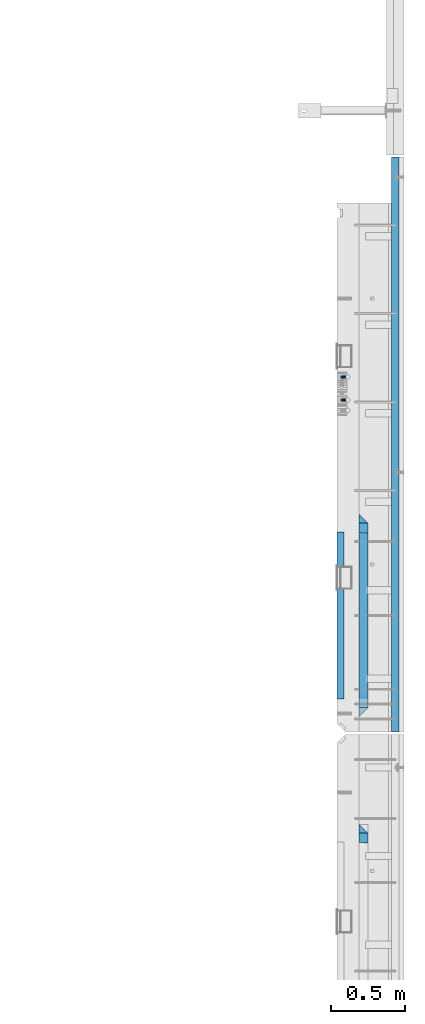
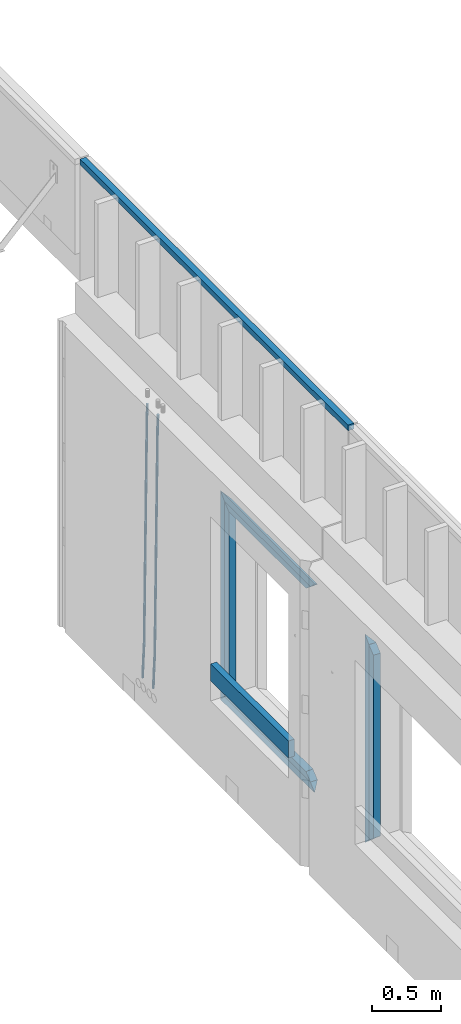
# One storey, part 44 of 153: 12 beams, 2 elements without a shape of their own.
"""IFC2X3 building model written with IfcOpenShell, lengths in millimetres."""

from ifc_helpers import new_model, si_unit, frame, origin_with_axes, place, context, subcontext, project, spatial, faceted_brep, material, type_object, element, aggregate, save


model = new_model("IFC2X3")

# Units and contexts
model_context = context("Model", 3, precision=1e-05, world=origin_with_axes())
body_context = subcontext(model_context, "Body", "Model", "MODEL_VIEW")
ifc_project = project(units=[si_unit("LENGTHUNIT", "METRE", prefix="MILLI"), si_unit("AREAUNIT", "SQUARE_METRE"), si_unit("VOLUMEUNIT", "CUBIC_METRE"), si_unit("MASSUNIT", "GRAM", prefix="KILO"), si_unit("TIMEUNIT", "SECOND"), si_unit("PLANEANGLEUNIT", "RADIAN"), si_unit("SOLIDANGLEUNIT", "STERADIAN"), si_unit("THERMODYNAMICTEMPERATUREUNIT", "DEGREE_CELSIUS"), si_unit("LUMINOUSINTENSITYUNIT", "LUMEN")], contexts=[model_context])

# Site, building, storey
site_placement = place(None, origin_with_axes())
site = spatial("IfcSite", under=ifc_project, at=site_placement, CompositionType="ELEMENT")
building_placement = place(site_placement, origin_with_axes())
building = spatial("IfcBuilding", under=site, at=building_placement, CompositionType="ELEMENT")
storey_placement = place(building_placement, origin_with_axes())
storey = spatial("IfcBuildingStorey", under=building, at=storey_placement, Name="8", CompositionType="ELEMENT", Elevation=0.0)

# Assembly, beams
assembly_1_placement = place(storey_placement, origin_with_axes())
assembly_1 = element("IfcElementAssembly", 1, at=assembly_1_placement, inside=storey, AssemblyPlace="NOTDEFINED", PredefinedType="REINFORCEMENT_UNIT")
ifc_material_1 = material()
beam_type_1 = type_object("IfcBeamType", Name="D20", PredefinedType="NOTDEFINED")
beam_1_placement = place(assembly_1_placement, frame((34944.9999977209, 19395.0002441367, 99990.0), z_axis=(0.999642804629538, 0.000205762999925497, -0.0267249099901003), x_axis=(0.0267249109941254, -4.30000210532798e-08, 0.999642825779465)))
beam_1 = element("IfcBeam", 2, at=beam_1_placement, type_object=beam_type_1, material=ifc_material_1, Name="JM20", ObjectType="D20", context=body_context, shape_type="Brep", body=[
    faceted_brep([(0.0, -10.0, 0.0), (-4.19531716033816e-08, -7.07106781186667, -7.07106781187031), (60.4266690400545, -7.0710677960451, -7.07106780570757), (60.4266690441291, -9.99999998418934, 6.15546014159918e-09), (0.0, 0.0, -10.0), (60.426669036824, 1.58106558956206e-08, -9.99999999384454), (4.196772351861e-08, 7.07106781186303, -7.07106781186667), (60.4266690363438, 7.07106782768096, -7.07106780570757), (0.0, 10.0, 0.0), (60.4266690388904, 10.0000000158179, 6.15182216279209e-09), (4.196772351861e-08, 7.07106781185939, 7.07106781185939), (60.4266690429649, 7.07106782768096, 7.07106781802577), (0.0, 0.0, 10.0), (60.4266690461809, 1.58179318532348e-08, 10.0000000061555), (-4.19531716033816e-08, -7.07106781187031, 7.07106781185939), (60.4266690466611, -7.07106779605238, 7.07106781802213), (61.0378400410118, -7.07106779588503, -7.07106780564936), (60.991799419251, -9.99999998403655, 6.21366780251265e-09), (61.0569027789461, 1.5985278878361e-08, -9.99999999378269), (61.0378209396877, 7.07106782784831, -7.07106780564936), (60.9917724058905, 10.0000000159635, 6.21366780251265e-09), (60.9457317841297, 7.07106782781193, 7.0710678180767), (60.9266690461809, 1.59488990902901e-08, 10.0000000062028), (60.9457508854539, -7.07106779591413, 7.0710678180767), (61.6489592143771, -7.07106614513759, -7.06310863441468), (61.5568818710308, -9.9999984576425, 0.00735959856683621), (61.6870830769039, 1.71821739058942e-06, -9.99179257185824), (61.6489210170112, 7.07106947854481, -7.06310888312146), (61.556827851804, 10.0000015422847, 0.00735924683976918), (61.4647505084577, 7.07106922979438, 7.07782747982128), (61.4266266459163, 1.36643211590126e-06, 10.0065114172685), (61.464788705809, -7.07106639389531, 7.07782772852806), (176.543135720174, -7.07075579406956, -5.56673531796696), (176.451058376813, -9.99968810657447, 1.50373291501455), (176.581259582701, 0.000312069292704109, -8.49541925541052), (176.543097522794, 7.07137982961285, -5.56673556667374), (176.451004357587, 10.00031189336, 1.50373256329476), (176.35892701424, 7.07137958085514, 8.57420079627263), (176.320803151699, 0.000311717507429421, 11.5028847337162), (176.358965211621, -7.07075604281999, 8.57420104497578), (177.098753836006, -7.07075429323595, -5.55949898843028), (176.98362511232, -9.99968666800123, 1.510669025065), (177.146421932586, 0.000313595905026887, -8.48805862247536), (177.098706077581, 7.07138133041735, -5.55949936166144), (176.983557571715, 10.0003133318824, 1.51066849724157), (176.868428848029, 7.07138095712435, 8.58083651073321), (176.820760751449, 0.000313067976094317, 11.5093961447819), (176.868476606425, -7.07075466652896, 8.58083688396073), (177.654312950661, -7.07075204110879, -5.54863964998367), (177.516135294456, -9.99968450931192, 1.52107783331303), (177.711524267797, 0.000315886711177882, -8.47701274570863), (177.654255632195, 7.07138358250813, -5.54864021007961), (177.516054233929, 10.0003154905207, 1.5210770412159), (177.377876577739, 7.0713830223176, 8.59079452451624), (177.320665260588, 0.000315094497636892, 11.5191676202448), (177.377933896176, -7.07075260129932, 8.59079508461218), (299.436796249574, -7.07025836271714, -3.1681962331204), (299.298618593355, -9.99919083092027, 3.90152125031091), (299.494007566798, 0.000809565110102994, -6.09656932889993), (299.436738931283, 7.07187726089978, -3.16819679320906), (299.298537533061, 10.0008091689197, 3.90152045822106), (299.160359876842, 7.07187670072017, 10.9712379416487), (299.103148559603, 0.000808772889286047, 13.8996110374392), (299.160417195119, -7.07025892290039, 10.9712385017483), (299.98743051647, -7.07025613056248, -3.15743315966392), (299.971788958996, -9.99918809853989, 3.91467979818117), (299.993912075952, 0.000811591617093654, -6.08679785393178), (299.987423933868, 7.07187949325817, -3.1574327280432), (299.971753863239, 10.0008119014747, 3.91467990454839), (299.95611230444, 7.07187992653053, 10.9867922621015), (299.949630744944, 0.000812204350950196, 13.9161569563694), (299.956118887014, -7.07025569729012, 10.9867918304735), (300.538107039494, -7.07025785017686, -3.16575821840888), (300.644985195438, -9.99919020432935, 3.90450175465594), (300.493854948218, 0.000810030429420294, -6.09435592770024), (300.538151196495, 7.071877773491, -3.16575855385963), (300.645047642858, 10.0008097955724, 3.90450128024895), (300.751925798773, 7.07187744142357, 10.9747612533101), (300.796177890064, 0.000809560813650023, 13.9033589625978), (300.751881641787, -7.07025818224065, 10.9747615887682), (2293.36490490142, -7.07648090940347, -33.2930642912361), (2293.47178305736, -10.0054132635523, -26.2228043181785), (2293.32065281013, -0.00541302880083094, -36.2216620005347), (2293.36494905842, 7.06565471425711, -33.2930646266868), (2293.47184550477, 9.99458673634581, -26.2228047925819), (2293.57872366071, 7.06565438219332, -19.1525448195243), (2293.62297575199, -0.00541349841296324, -16.2239471102366), (2293.57867950371, -7.0764812414709, -19.1525444840736), (2294.0658245362, -7.07648309818615, -33.3036607065333), (2294.05312277409, -10.0054150789219, -26.2315929392535), (2294.10928714235, -0.00541549149056664, -36.2335844756526), (2294.15805078732, 7.06565223761572, -33.3050546393533), (2294.18355038921, 9.99458451388637, -26.2335642579346), (2294.17084862708, 7.06565253314329, -19.1614964906439), (2294.12738602093, -0.00541507354500936, -16.2315727215355), (2294.07862237596, -7.07648280265857, -19.1601025578348), (2294.76670261032, -7.08562269121467, -33.294332712383), (2294.63442802057, -10.0129954178956, -26.2238563411993), (2294.89787471293, -0.0156988342423574, -36.2230891548279), (2294.95110548967, 7.05531064255774, -33.2944998654275), (2294.89521307347, 9.98530428734011, -26.2240927312887), (2294.76293848372, 7.0579315606592, -19.1536163601049), (2294.63176638114, -0.0119922963167483, -16.2248599176673), (2294.57853560438, -7.08300177311321, -19.1534492070678), (2316.52657204497, -7.36937582653991, -33.0047303660212), (2316.39429745522, -10.2967485532172, -25.9342539948302), (2316.65774414754, -0.299451969567599, -35.9334868084661), (2316.7109749243, 6.7715575072325, -33.0048975190657), (2316.65508250811, 9.70155115201487, -25.9344903849269), (2316.52280791836, 6.7741784253376, -18.8640140137468), (2316.39163581574, -0.295745431634714, -15.9352575713092), (2316.33840503903, -7.36675490843481, -18.863846860706), (2317.16202064224, -7.37766220584308, -32.9962731735213), (2317.05438744847, -10.3053562613532, -25.9254688497131), (2317.23607125619, -0.306993473008333, -35.925789846493), (2317.23316144495, 6.76474808850253, -32.9979477328052), (2317.15499573652, 9.6950321815566, -25.9278370341635), (2317.04736254275, 6.7673381260538, -18.8570327103698), (2316.97331192881, -0.303330606784584, -15.9275160373909), (2316.97622174003, -7.37507216829545, -18.8553581510787), (2317.79752306276, -7.37578610372293, -32.9880110666527), (2317.71453320107, -10.3033876998124, -25.9168792378296), (2317.81444760226, -0.305295583297266, -35.918287695793), (2317.75539265381, 6.76628640723357, -32.9911928173897), (2317.65495180529, 9.69652304524061, -25.9213789128698), (2317.5719619436, 6.76892144914746, -18.8502470840467), (2317.55503740412, -0.301569071270933, -15.9199704549137), (2317.61409235255, -7.3731510618054, -18.847065333317), (2417.8183084176, -7.07752398473531, -31.6906369377139), (2417.73531855589, -10.0051255808248, -24.6195051088798), (2417.83523295709, -0.007033464313281, -34.6209135668432), (2417.77617800863, 7.06454852621755, -31.6938186884508), (2417.67573716014, 9.99478516423187, -24.6240047839383), (2417.59274729842, 7.06718356813872, -17.5528729551006), (2417.57582275895, -0.00330695228694822, -14.6225963259749), (2417.6348777074, -7.07488894281778, -17.5496912043673)], [[[0, 1, 2, 3]], [[1, 4, 5, 2]], [[4, 6, 7, 5]], [[6, 8, 9, 7]], [[8, 10, 11, 9]], [[10, 12, 13, 11]], [[12, 14, 15, 13]], [[14, 0, 3, 15]], [[14, 12, 10, 8, 6, 4, 1, 0]], [[3, 2, 16, 17]], [[2, 5, 18, 16]], [[5, 7, 19, 18]], [[7, 9, 20, 19]], [[9, 11, 21, 20]], [[11, 13, 22, 21]], [[13, 15, 23, 22]], [[15, 3, 17, 23]], [[17, 16, 24, 25]], [[16, 18, 26, 24]], [[18, 19, 27, 26]], [[19, 20, 28, 27]], [[20, 21, 29, 28]], [[21, 22, 30, 29]], [[22, 23, 31, 30]], [[23, 17, 25, 31]], [[25, 24, 32, 33]], [[24, 26, 34, 32]], [[26, 27, 35, 34]], [[27, 28, 36, 35]], [[28, 29, 37, 36]], [[29, 30, 38, 37]], [[30, 31, 39, 38]], [[31, 25, 33, 39]], [[33, 32, 40, 41]], [[32, 34, 42, 40]], [[34, 35, 43, 42]], [[35, 36, 44, 43]], [[36, 37, 45, 44]], [[37, 38, 46, 45]], [[38, 39, 47, 46]], [[39, 33, 41, 47]], [[41, 40, 48, 49]], [[40, 42, 50, 48]], [[42, 43, 51, 50]], [[43, 44, 52, 51]], [[44, 45, 53, 52]], [[45, 46, 54, 53]], [[46, 47, 55, 54]], [[47, 41, 49, 55]], [[49, 48, 56, 57]], [[48, 50, 58, 56]], [[50, 51, 59, 58]], [[51, 52, 60, 59]], [[52, 53, 61, 60]], [[53, 54, 62, 61]], [[54, 55, 63, 62]], [[55, 49, 57, 63]], [[57, 56, 64, 65]], [[56, 58, 66, 64]], [[58, 59, 67, 66]], [[59, 60, 68, 67]], [[60, 61, 69, 68]], [[61, 62, 70, 69]], [[62, 63, 71, 70]], [[63, 57, 65, 71]], [[65, 64, 72, 73]], [[64, 66, 74, 72]], [[66, 67, 75, 74]], [[67, 68, 76, 75]], [[68, 69, 77, 76]], [[69, 70, 78, 77]], [[70, 71, 79, 78]], [[71, 65, 73, 79]], [[73, 72, 80, 81]], [[72, 74, 82, 80]], [[74, 75, 83, 82]], [[75, 76, 84, 83]], [[76, 77, 85, 84]], [[77, 78, 86, 85]], [[78, 79, 87, 86]], [[79, 73, 81, 87]], [[81, 80, 88, 89]], [[80, 82, 90, 88]], [[82, 83, 91, 90]], [[83, 84, 92, 91]], [[84, 85, 93, 92]], [[85, 86, 94, 93]], [[86, 87, 95, 94]], [[87, 81, 89, 95]], [[89, 88, 96, 97]], [[88, 90, 98, 96]], [[90, 91, 99, 98]], [[91, 92, 100, 99]], [[92, 93, 101, 100]], [[93, 94, 102, 101]], [[94, 95, 103, 102]], [[95, 89, 97, 103]], [[97, 96, 104, 105]], [[96, 98, 106, 104]], [[98, 99, 107, 106]], [[99, 100, 108, 107]], [[100, 101, 109, 108]], [[101, 102, 110, 109]], [[102, 103, 111, 110]], [[103, 97, 105, 111]], [[105, 104, 112, 113]], [[104, 106, 114, 112]], [[106, 107, 115, 114]], [[107, 108, 116, 115]], [[108, 109, 117, 116]], [[109, 110, 118, 117]], [[110, 111, 119, 118]], [[111, 105, 113, 119]], [[113, 112, 120, 121]], [[112, 114, 122, 120]], [[114, 115, 123, 122]], [[115, 116, 124, 123]], [[116, 117, 125, 124]], [[117, 118, 126, 125]], [[118, 119, 127, 126]], [[119, 113, 121, 127]], [[121, 120, 128, 129]], [[120, 122, 130, 128]], [[122, 123, 131, 130]], [[123, 124, 132, 131]], [[124, 125, 133, 132]], [[125, 126, 134, 133]], [[126, 127, 135, 134]], [[127, 121, 129, 135]], [[130, 131, 132, 133, 134, 135, 129, 128]]]),
])
beam_2_placement = place(assembly_1_placement, frame((34944.9999977209, 19240.0002441367, 99990.0), z_axis=(0.999642804629538, 0.000205762999925497, -0.0267249099901003), x_axis=(0.0267249109941254, -4.30000210532798e-08, 0.999642825779465)))
beam_2 = element("IfcBeam", 3, at=beam_2_placement, type_object=beam_type_1, material=ifc_material_1, Name="JM20", ObjectType="D20", context=body_context, shape_type="Brep", body=[
    faceted_brep([(0.0, -10.0, 0.0), (-4.19531716033816e-08, -7.07106781186667, -7.07106781187031), (60.4266690400545, -7.0710677960451, -7.07106780570757), (60.4266690441291, -9.99999998418934, 6.15546014159918e-09), (0.0, 0.0, -10.0), (60.426669036824, 1.58106558956206e-08, -9.99999999384454), (4.196772351861e-08, 7.07106781186303, -7.07106781186667), (60.4266690363438, 7.07106782768096, -7.07106780570757), (0.0, 10.0, 0.0), (60.4266690388904, 10.0000000158179, 6.15182216279209e-09), (4.196772351861e-08, 7.07106781185939, 7.07106781185939), (60.4266690429649, 7.07106782768096, 7.07106781802577), (0.0, 0.0, 10.0), (60.4266690461809, 1.58179318532348e-08, 10.0000000061555), (-4.19531716033816e-08, -7.07106781187031, 7.07106781185939), (60.4266690466611, -7.07106779605238, 7.07106781802213), (61.0378400410118, -7.07106779588503, -7.07106780564936), (60.991799419251, -9.99999998403655, 6.21366780251265e-09), (61.0569027789461, 1.5985278878361e-08, -9.99999999378269), (61.0378209396877, 7.07106782784831, -7.07106780564936), (60.9917724058905, 10.0000000159635, 6.21366780251265e-09), (60.9457317841297, 7.07106782781193, 7.0710678180767), (60.9266690461809, 1.59488990902901e-08, 10.0000000062028), (60.9457508854539, -7.07106779591413, 7.0710678180767), (61.6489592143771, -7.07106614513759, -7.06310863441468), (61.5568818710308, -9.9999984576425, 0.00735959856683621), (61.6870830769039, 1.71821739058942e-06, -9.99179257185824), (61.6489210170112, 7.07106947854481, -7.06310888312146), (61.556827851804, 10.0000015422847, 0.00735924683976918), (61.4647505084577, 7.07106922979438, 7.07782747982128), (61.4266266459163, 1.36643211590126e-06, 10.0065114172685), (61.464788705809, -7.07106639389531, 7.07782772852806), (176.543135720174, -7.07075579406956, -5.56673531796696), (176.451058376813, -9.99968810657447, 1.50373291501455), (176.581259582701, 0.000312069292704109, -8.49541925541052), (176.543097522794, 7.07137982961285, -5.56673556667374), (176.451004357587, 10.00031189336, 1.50373256329476), (176.35892701424, 7.07137958085514, 8.57420079627263), (176.320803151699, 0.000311717507429421, 11.5028847337162), (176.358965211621, -7.07075604281999, 8.57420104497578), (177.098753836006, -7.07075429323595, -5.55949898843028), (176.98362511232, -9.99968666800123, 1.510669025065), (177.146421932586, 0.000313595905026887, -8.48805862247536), (177.098706077581, 7.07138133041735, -5.55949936166144), (176.983557571715, 10.0003133318824, 1.51066849724157), (176.868428848029, 7.07138095712435, 8.58083651073321), (176.820760751449, 0.000313067976094317, 11.5093961447819), (176.868476606425, -7.07075466652896, 8.58083688396073), (177.654312950661, -7.07075204110879, -5.54863964998367), (177.516135294456, -9.99968450931192, 1.52107783331303), (177.711524267797, 0.000315886711177882, -8.47701274570863), (177.654255632195, 7.07138358250813, -5.54864021007961), (177.516054233929, 10.0003154905207, 1.5210770412159), (177.377876577739, 7.0713830223176, 8.59079452451624), (177.320665260588, 0.000315094497636892, 11.5191676202448), (177.377933896176, -7.07075260129932, 8.59079508461218), (299.436796249574, -7.07025836271714, -3.1681962331204), (299.298618593355, -9.99919083092027, 3.90152125031091), (299.494007566798, 0.000809565110102994, -6.09656932889993), (299.436738931283, 7.07187726089978, -3.16819679320906), (299.298537533061, 10.0008091689197, 3.90152045822106), (299.160359876842, 7.07187670072017, 10.9712379416487), (299.103148559603, 0.000808772889286047, 13.8996110374392), (299.160417195119, -7.07025892290039, 10.9712385017483), (299.98743051647, -7.07025613056248, -3.15743315966392), (299.971788958996, -9.99918809853989, 3.91467979818117), (299.993912075952, 0.000811591617093654, -6.08679785393178), (299.987423933868, 7.07187949325817, -3.1574327280432), (299.971753863239, 10.0008119014747, 3.91467990454839), (299.95611230444, 7.07187992653053, 10.9867922621015), (299.949630744944, 0.000812204350950196, 13.9161569563694), (299.956118887014, -7.07025569729012, 10.9867918304735), (300.538107039494, -7.07025785017686, -3.16575821840888), (300.644985195438, -9.99919020432935, 3.90450175465594), (300.493854948218, 0.000810030429420294, -6.09435592770024), (300.538151196495, 7.071877773491, -3.16575855385963), (300.645047642858, 10.0008097955724, 3.90450128024895), (300.751925798773, 7.07187744142357, 10.9747612533101), (300.796177890064, 0.000809560813650023, 13.9033589625978), (300.751881641787, -7.07025818224065, 10.9747615887682), (2293.36490490142, -7.07648090940347, -33.2930642912361), (2293.47178305736, -10.0054132635523, -26.2228043181785), (2293.32065281013, -0.00541302880083094, -36.2216620005347), (2293.36494905842, 7.06565471425711, -33.2930646266868), (2293.47184550477, 9.99458673634581, -26.2228047925819), (2293.57872366071, 7.06565438219332, -19.1525448195243), (2293.62297575199, -0.00541349841296324, -16.2239471102366), (2293.57867950371, -7.0764812414709, -19.1525444840736), (2294.0658245362, -7.07648309818615, -33.3036607065333), (2294.05312277409, -10.0054150789219, -26.2315929392535), (2294.10928714235, -0.00541549149056664, -36.2335844756526), (2294.15805078732, 7.06565223761572, -33.3050546393533), (2294.18355038921, 9.99458451388637, -26.2335642579346), (2294.17084862708, 7.06565253314329, -19.1614964906439), (2294.12738602093, -0.00541507354500936, -16.2315727215355), (2294.07862237596, -7.07648280265857, -19.1601025578348), (2294.76670261032, -7.08562269121467, -33.294332712383), (2294.63442802057, -10.0129954178956, -26.2238563411993), (2294.89787471293, -0.0156988342423574, -36.2230891548279), (2294.95110548967, 7.05531064255774, -33.2944998654275), (2294.89521307347, 9.98530428734011, -26.2240927312887), (2294.76293848372, 7.0579315606592, -19.1536163601049), (2294.63176638114, -0.0119922963167483, -16.2248599176673), (2294.57853560438, -7.08300177311321, -19.1534492070678), (2316.52657204497, -7.36937582653991, -33.0047303660212), (2316.39429745522, -10.2967485532172, -25.9342539948302), (2316.65774414754, -0.299451969567599, -35.9334868084661), (2316.7109749243, 6.7715575072325, -33.0048975190657), (2316.65508250811, 9.70155115201487, -25.9344903849269), (2316.52280791836, 6.7741784253376, -18.8640140137468), (2316.39163581574, -0.295745431634714, -15.9352575713092), (2316.33840503903, -7.36675490843481, -18.863846860706), (2317.16202064224, -7.37766220584308, -32.9962731735213), (2317.05438744847, -10.3053562613532, -25.9254688497131), (2317.23607125619, -0.306993473008333, -35.925789846493), (2317.23316144495, 6.76474808850253, -32.9979477328052), (2317.15499573652, 9.6950321815566, -25.9278370341635), (2317.04736254275, 6.7673381260538, -18.8570327103698), (2316.97331192881, -0.303330606784584, -15.9275160373909), (2316.97622174003, -7.37507216829545, -18.8553581510787), (2317.79752306276, -7.37578610372293, -32.9880110666527), (2317.71453320107, -10.3033876998124, -25.9168792378296), (2317.81444760226, -0.305295583297266, -35.918287695793), (2317.75539265381, 6.76628640723357, -32.9911928173897), (2317.65495180529, 9.69652304524061, -25.9213789128698), (2317.5719619436, 6.76892144914746, -18.8502470840467), (2317.55503740412, -0.301569071270933, -15.9199704549137), (2317.61409235255, -7.3731510618054, -18.847065333317), (2417.8183084176, -7.07752398473531, -31.6906369377139), (2417.73531855589, -10.0051255808248, -24.6195051088798), (2417.83523295709, -0.007033464313281, -34.6209135668432), (2417.77617800863, 7.06454852621755, -31.6938186884508), (2417.67573716014, 9.99478516423187, -24.6240047839383), (2417.59274729842, 7.06718356813872, -17.5528729551006), (2417.57582275895, -0.00330695228694822, -14.6225963259749), (2417.6348777074, -7.07488894281778, -17.5496912043673)], [[[0, 1, 2, 3]], [[1, 4, 5, 2]], [[4, 6, 7, 5]], [[6, 8, 9, 7]], [[8, 10, 11, 9]], [[10, 12, 13, 11]], [[12, 14, 15, 13]], [[14, 0, 3, 15]], [[14, 12, 10, 8, 6, 4, 1, 0]], [[3, 2, 16, 17]], [[2, 5, 18, 16]], [[5, 7, 19, 18]], [[7, 9, 20, 19]], [[9, 11, 21, 20]], [[11, 13, 22, 21]], [[13, 15, 23, 22]], [[15, 3, 17, 23]], [[17, 16, 24, 25]], [[16, 18, 26, 24]], [[18, 19, 27, 26]], [[19, 20, 28, 27]], [[20, 21, 29, 28]], [[21, 22, 30, 29]], [[22, 23, 31, 30]], [[23, 17, 25, 31]], [[25, 24, 32, 33]], [[24, 26, 34, 32]], [[26, 27, 35, 34]], [[27, 28, 36, 35]], [[28, 29, 37, 36]], [[29, 30, 38, 37]], [[30, 31, 39, 38]], [[31, 25, 33, 39]], [[33, 32, 40, 41]], [[32, 34, 42, 40]], [[34, 35, 43, 42]], [[35, 36, 44, 43]], [[36, 37, 45, 44]], [[37, 38, 46, 45]], [[38, 39, 47, 46]], [[39, 33, 41, 47]], [[41, 40, 48, 49]], [[40, 42, 50, 48]], [[42, 43, 51, 50]], [[43, 44, 52, 51]], [[44, 45, 53, 52]], [[45, 46, 54, 53]], [[46, 47, 55, 54]], [[47, 41, 49, 55]], [[49, 48, 56, 57]], [[48, 50, 58, 56]], [[50, 51, 59, 58]], [[51, 52, 60, 59]], [[52, 53, 61, 60]], [[53, 54, 62, 61]], [[54, 55, 63, 62]], [[55, 49, 57, 63]], [[57, 56, 64, 65]], [[56, 58, 66, 64]], [[58, 59, 67, 66]], [[59, 60, 68, 67]], [[60, 61, 69, 68]], [[61, 62, 70, 69]], [[62, 63, 71, 70]], [[63, 57, 65, 71]], [[65, 64, 72, 73]], [[64, 66, 74, 72]], [[66, 67, 75, 74]], [[67, 68, 76, 75]], [[68, 69, 77, 76]], [[69, 70, 78, 77]], [[70, 71, 79, 78]], [[71, 65, 73, 79]], [[73, 72, 80, 81]], [[72, 74, 82, 80]], [[74, 75, 83, 82]], [[75, 76, 84, 83]], [[76, 77, 85, 84]], [[77, 78, 86, 85]], [[78, 79, 87, 86]], [[79, 73, 81, 87]], [[81, 80, 88, 89]], [[80, 82, 90, 88]], [[82, 83, 91, 90]], [[83, 84, 92, 91]], [[84, 85, 93, 92]], [[85, 86, 94, 93]], [[86, 87, 95, 94]], [[87, 81, 89, 95]], [[89, 88, 96, 97]], [[88, 90, 98, 96]], [[90, 91, 99, 98]], [[91, 92, 100, 99]], [[92, 93, 101, 100]], [[93, 94, 102, 101]], [[94, 95, 103, 102]], [[95, 89, 97, 103]], [[97, 96, 104, 105]], [[96, 98, 106, 104]], [[98, 99, 107, 106]], [[99, 100, 108, 107]], [[100, 101, 109, 108]], [[101, 102, 110, 109]], [[102, 103, 111, 110]], [[103, 97, 105, 111]], [[105, 104, 112, 113]], [[104, 106, 114, 112]], [[106, 107, 115, 114]], [[107, 108, 116, 115]], [[108, 109, 117, 116]], [[109, 110, 118, 117]], [[110, 111, 119, 118]], [[111, 105, 113, 119]], [[113, 112, 120, 121]], [[112, 114, 122, 120]], [[114, 115, 123, 122]], [[115, 116, 124, 123]], [[116, 117, 125, 124]], [[117, 118, 126, 125]], [[118, 119, 127, 126]], [[119, 113, 121, 127]], [[121, 120, 128, 129]], [[120, 122, 130, 128]], [[122, 123, 131, 130]], [[123, 124, 132, 131]], [[124, 125, 133, 132]], [[125, 126, 134, 133]], [[126, 127, 135, 134]], [[127, 121, 129, 135]], [[130, 131, 132, 133, 134, 135, 129, 128]]]),
])
ifc_material_2 = material(Name="TIMBER/T24")
beam_type_2 = type_object("IfcBeamType", Name="PK50X50", PredefinedType="NOTDEFINED")
beam_3_placement = place(assembly_1_placement, frame((35305.0, 20885.0002441406, 103545.0), z_axis=(0.0, 0.0, 1.0), x_axis=(0.0, -1.0, 0.0)))
beam_3 = element("IfcBeam", 4, at=beam_3_placement, type_object=beam_type_2, material=ifc_material_2, ObjectType="PK50X50", context=body_context, shape_type="Brep", body=[
    faceted_brep([(0.0, 25.0, 25.0), (0.0, -25.0, 25.0), (3895.0, -25.0, 25.0), (3895.0, 25.0, 25.0), (0.0, -25.0, -25.0), (3895.0, -25.0, -25.0), (0.0, 25.0, -25.0), (3895.0, 25.0, -25.0)], [[[0, 1, 2, 3]], [[1, 4, 5, 2]], [[4, 6, 7, 5]], [[6, 0, 3, 7]], [[5, 7, 3, 2]], [[4, 1, 0, 6]]]),
])
beam_type_3 = type_object("IfcBeamType", PredefinedType="NOTDEFINED")
beam_4_placement = place(assembly_1_placement, frame((34935.0002758707, 17215.0011464907, 100685.0), z_axis=(0.0, 0.0, 1.0), x_axis=(0.0, 1.0, 0.0)))
beam_4 = element("IfcBeam", 5, at=beam_4_placement, type_object=beam_type_3, material=ifc_material_2, context=body_context, shape_type="Brep", body=[
    faceted_brep([(-3.63797880709171e-12, 24.9999999999964, -75.0), (-3.63797880709171e-12, 24.9999999999964, 75.0), (1130.0, 25.0, 75.0), (1130.0, 25.0, -75.0), (0.0, -25.0000000000073, 75.0), (1130.0, -25.0, 75.0), (0.0, -25.0000000000073, -75.0), (1130.0, -25.0, -75.0)], [[[0, 1, 2, 3]], [[1, 4, 5, 2]], [[4, 6, 7, 5]], [[6, 0, 3, 7]], [[5, 7, 3, 2]], [[6, 4, 1, 0]]]),
])
ifc_material_3 = material(Name="CONCRETE/C25/30")
beam_type_4 = type_object("IfcBeamType", PredefinedType="NOTDEFINED")
beam_5_placement = place(assembly_1_placement, frame((35090.0, 17095.0018965848, 102145.0), z_axis=(0.0, 0.0, -1.0), x_axis=(0.0, 1.0, 0.0)))
beam_5 = element("IfcBeam", 6, at=beam_5_placement, type_object=beam_type_4, material=ifc_material_3, Name="SK", context=body_context, shape_type="Brep", body=[
    faceted_brep([(60.0000000000073, 30.0, 30.0), (0.0, -30.0, -30.0), (60.0000000000073, -30.0, 30.0), (1309.99847412109, 30.0, 30.0), (1369.99847412109, -30.0, -30.0), (1309.99847412109, -30.0, 30.0)], [[[0, 1, 2]], [[1, 0, 3, 4]], [[2, 1, 4, 5]], [[0, 2, 5, 3]], [[3, 5, 4]]]),
])
beam_6_placement = place(assembly_1_placement, frame((35090.0, 17155.0018965848, 102085.0), z_axis=(0.0, 0.0, -1.0), x_axis=(0.0, 1.0, 0.0)))
beam_6 = element("IfcBeam", 7, at=beam_6_placement, type_object=beam_type_4, material=ifc_material_3, Name="SK", context=body_context, shape_type="Brep", body=[
    faceted_brep([(1185.94442006696, -29.999999998452, 24.0540540541406), (1184.32279844542, 29.999999998452, 25.6756756756804), (65.6741497967687, 29.999999998452, 25.6756756756804), (64.0525281752307, -29.999999998452, 24.0540540541406), (65.6741497967687, 29.999999998452, 26.2921283848846), (64.0525281752307, -29.999999998452, 24.9021669953072), (0.0, 30.0, -30.0), (0.0, -30.0, -30.0), (1249.99847412109, 29.999999998452, -30.0), (1249.99847412109, -29.999999998452, -30.0), (1185.94442006696, -29.999999998452, 24.9034748915001), (1184.32279844542, 29.999999998452, 26.2934362810629)], [[[0, 1, 2, 3]], [[3, 2, 4, 5]], [[4, 6, 7, 5]], [[7, 6, 8, 9]], [[0, 3, 5, 7, 9, 10]], [[1, 0, 10, 11]], [[6, 4, 2, 1, 11, 8]], [[8, 11, 10, 9]]]),
])
beam_7_placement = place(assembly_1_placement, frame((35090.0, 18435.0003707059, 102175.0), z_axis=(0.0, -1.0, 0.0), x_axis=(0.0, 0.0, -1.0)))
beam_7 = element("IfcBeam", 8, at=beam_7_placement, type_object=beam_type_4, material=ifc_material_3, Name="SK", context=body_context, shape_type="Brep", body=[
    faceted_brep([(60.0000000000073, 30.0, 30.0), (0.0, -30.0, -30.0), (60.0000000000073, -30.0, 30.0), (1795.00000000001, 30.0, 30.0), (1855.0, -30.0, -30.0), (1795.00000000001, -30.0, 30.0)], [[[0, 1, 2]], [[3, 4, 1, 0]], [[4, 5, 2, 1]], [[5, 3, 0, 2]], [[5, 4, 3]]]),
])
beam_8_placement = place(assembly_1_placement, frame((35090.0, 18465.0003707059, 100350.0), z_axis=(0.0, 0.0, 1.0), x_axis=(0.0, -1.0, 0.0)))
beam_8 = element("IfcBeam", 9, at=beam_8_placement, type_object=beam_type_4, material=ifc_material_3, Name="SK", context=body_context, shape_type="Brep", body=[
    faceted_brep([(1309.99847412109, 30.0, 30.0), (1309.99847412109, -30.0, 30.0), (1369.99847412109, -30.0, -30.0), (60.0000000000073, 30.0, 30.0), (60.0000000000073, -30.0, 30.0), (0.0, -30.0, -30.0)], [[[0, 1, 2]], [[3, 4, 1, 0]], [[4, 5, 2, 1]], [[5, 3, 0, 2]], [[3, 5, 4]]]),
])
beam_9_placement = place(assembly_1_placement, frame((35090.0, 18405.0003707059, 100410.0), z_axis=(0.0, 0.0, 1.0), x_axis=(0.0, -1.0, 0.0)))
beam_9 = element("IfcBeam", 10, at=beam_9_placement, type_object=beam_type_4, material=ifc_material_3, Name="SK", context=body_context, shape_type="Brep", body=[
    faceted_brep([(1185.94594588314, -29.9999988381387, 24.0540541168593), (1184.32432432432, 29.9999988381387, 25.6756756756804), (65.6756756756768, 30.0, 25.6756756756804), (64.0540540540533, -30.0, 24.0540540540533), (1185.94594594586, -29.999999998452, 24.9021669952926), (1184.32432432433, 29.999999998452, 26.2921283848846), (1249.99847412109, -29.999999998452, -30.0), (1249.99847412109, 29.999999998452, -30.0), (0.0, 30.0, -30.0), (65.6756756756768, 30.0, 26.293436281092), (64.0540540540533, -30.0, 24.9034748914419), (0.0, -30.0, -30.0)], [[[0, 1, 2, 3]], [[1, 0, 4, 5]], [[5, 4, 6, 7]], [[2, 1, 5, 7, 8, 9]], [[3, 2, 9, 10]], [[6, 4, 0, 3, 10, 11]], [[11, 8, 7, 6]], [[11, 10, 9, 8]]]),
])

# Assembly, beam
assembly_2_placement = place(storey_placement, origin_with_axes())
assembly_2 = element("IfcElementAssembly", 11, at=assembly_2_placement, inside=storey, AssemblyPlace="NOTDEFINED", PredefinedType="REINFORCEMENT_UNIT")
beam_10_placement = place(assembly_2_placement, frame((35090.0, 16335.0003479451, 102175.0), z_axis=(0.0, -1.0, 0.0), x_axis=(0.0, 0.0, -1.0)))
beam_10 = element("IfcBeam", 12, at=beam_10_placement, type_object=beam_type_4, material=ifc_material_3, Name="SK", context=body_context, shape_type="Brep", body=[
    faceted_brep([(60.0000000000073, 30.0, 30.0), (0.0, -30.0, -30.0), (60.0000000000073, -30.0, 30.0), (1795.00000000001, 30.0, 30.0), (1855.0, -30.0, -30.0), (1795.00000000001, -30.0, 30.0)], [[[0, 1, 2]], [[3, 4, 1, 0]], [[4, 5, 2, 1]], [[5, 3, 0, 2]], [[5, 4, 3]]]),
])

# Beam
beam_type_5 = type_object("IfcBeamType", PredefinedType="NOTDEFINED")
beam_11_placement = place(assembly_1_placement, frame((35090.0, 18370.0003707059, 102115.0), z_axis=(0.0, -1.0, 0.0), x_axis=(0.0, 0.0, -1.0)))
beam_11 = element("IfcBeam", 13, at=beam_11_placement, type_object=beam_type_5, material=ifc_material_3, Name="SK", context=body_context, shape_type="Brep", body=[
    faceted_brep([(0.0, -30.0, -35.0), (54.9034748914273, -30.0, 29.0540540540533), (56.2934362811066, 30.0, 30.6756756756768), (0.0, 30.0, -35.0), (1735.0, 30.0, -35.0), (1735.0, -30.0, -35.0), (1680.09652510857, -30.0, 29.0540540540533), (1678.70656371891, 30.0, 30.6756756756768)], [[[0, 1, 2, 3]], [[4, 5, 0, 3]], [[1, 0, 5, 6]], [[2, 1, 6, 7]], [[3, 2, 7, 4]], [[5, 4, 7, 6]]]),
])

aggregate(assembly_1, [beam_3, beam_1, beam_2, beam_5, beam_6, beam_7, beam_11, beam_8, beam_9, beam_4])

beam_12_placement = place(assembly_2_placement, frame((35090.0, 16270.0003479451, 102115.0), z_axis=(0.0, -1.0, 0.0), x_axis=(0.0, 0.0, -1.0)))
beam_12 = element("IfcBeam", 14, at=beam_12_placement, type_object=beam_type_5, material=ifc_material_3, Name="SK", context=body_context, shape_type="Brep", body=[
    faceted_brep([(0.0, -30.0, -35.0), (54.9034748914273, -30.0, 29.0540540540533), (56.2934362811066, 30.0, 30.6756756756768), (0.0, 30.0, -35.0), (1735.0, 30.0, -35.0), (1735.0, -30.0, -35.0), (1680.09652510857, -30.0, 29.0540540540533), (1678.70656371891, 30.0, 30.6756756756768)], [[[0, 1, 2, 3]], [[4, 5, 0, 3]], [[1, 0, 5, 6]], [[2, 1, 6, 7]], [[3, 2, 7, 4]], [[5, 4, 7, 6]]]),
])

aggregate(assembly_2, [beam_10, beam_12])

save(model, "model.ifc")
